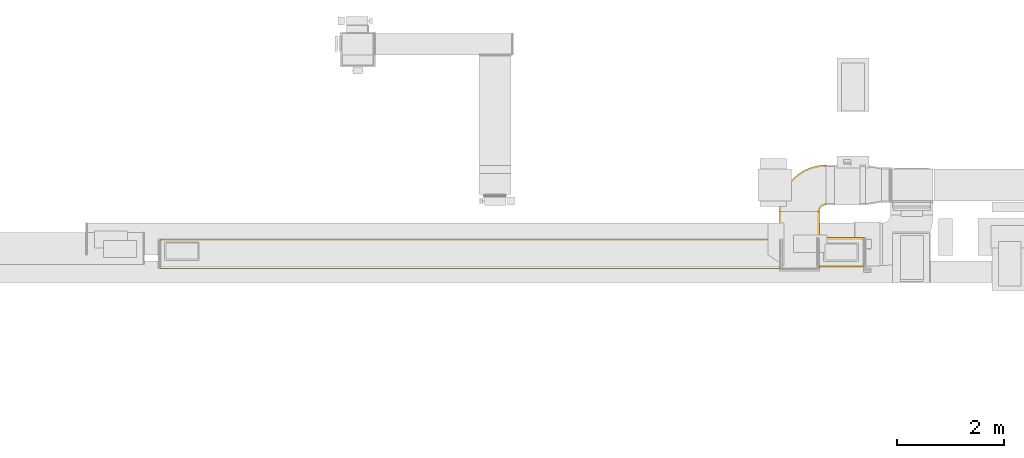
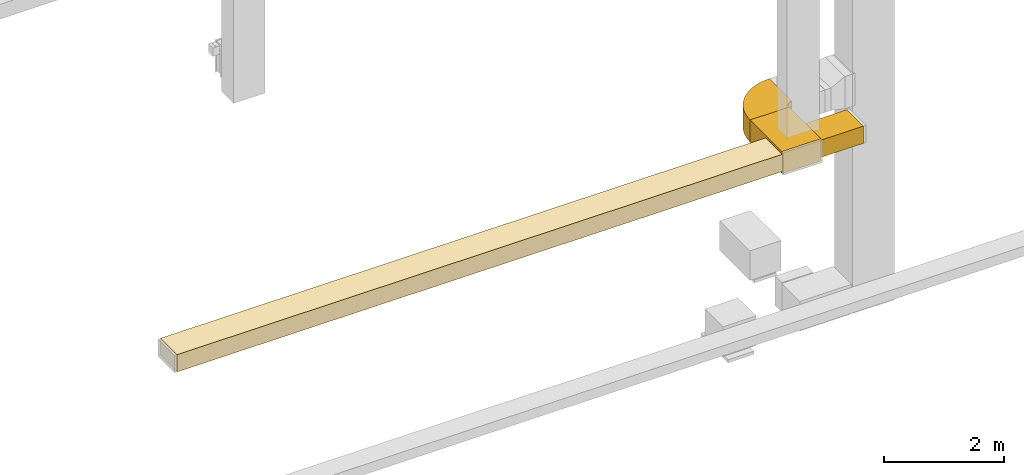
# One storey, part 2 of 29: 4 coverings.
"""IFC2X3 building model written with IfcOpenShell, lengths in millimetres."""

from ifc_helpers import new_model, entity, si_unit, converted_unit, derived_unit, direction, frame, frame_2d, origin, place, context, subcontext, project, spatial, polyline, circle_curve, parameter, trimmed, segment, composite_curve, rectangle, outline, extrude, element, save


model = new_model("IFC2X3")

# Units and contexts
model_context = context("Model", 3, precision=0.01, world=origin(), true_north=direction((6.12303176911189e-17, 1.0)))
body_context = subcontext(model_context, "Body", "Model", "MODEL_VIEW")
ifc_project = project(units=[si_unit("LENGTHUNIT", "METRE", prefix="MILLI"), si_unit("AREAUNIT", "SQUARE_METRE"), si_unit("VOLUMEUNIT", "CUBIC_METRE"), converted_unit("PLANEANGLEUNIT", "DEGREE", entity("IfcRatioMeasure", 0.0174532925199433), si_unit("PLANEANGLEUNIT", "RADIAN"), dimensions=[0, 0, 0, 0, 0, 0, 0]), si_unit("MASSUNIT", "GRAM", prefix="KILO"), derived_unit("MASSDENSITYUNIT", [(si_unit("MASSUNIT", "GRAM", prefix="KILO"), 1), (si_unit("LENGTHUNIT", "METRE"), -3)]), derived_unit("MOMENTOFINERTIAUNIT", [(si_unit("LENGTHUNIT", "METRE"), 4)]), si_unit("TIMEUNIT", "SECOND"), si_unit("FREQUENCYUNIT", "HERTZ"), si_unit("THERMODYNAMICTEMPERATUREUNIT", "DEGREE_CELSIUS"), derived_unit("THERMALTRANSMITTANCEUNIT", [(si_unit("MASSUNIT", "GRAM", prefix="KILO"), 1), (si_unit("THERMODYNAMICTEMPERATUREUNIT", "KELVIN"), -1), (si_unit("TIMEUNIT", "SECOND"), -3)]), derived_unit("VOLUMETRICFLOWRATEUNIT", [(si_unit("LENGTHUNIT", "METRE"), 3), (si_unit("TIMEUNIT", "SECOND"), -1)]), derived_unit("MASSFLOWRATEUNIT", [(si_unit("MASSUNIT", "GRAM", prefix="KILO"), 1), (si_unit("TIMEUNIT", "SECOND"), -1)]), derived_unit("ROTATIONALFREQUENCYUNIT", [(si_unit("TIMEUNIT", "SECOND"), -1)]), si_unit("ELECTRICCURRENTUNIT", "AMPERE"), si_unit("ELECTRICVOLTAGEUNIT", "VOLT"), si_unit("POWERUNIT", "WATT"), si_unit("FORCEUNIT", "NEWTON", prefix="KILO"), si_unit("ILLUMINANCEUNIT", "LUX"), si_unit("LUMINOUSFLUXUNIT", "LUMEN"), si_unit("LUMINOUSINTENSITYUNIT", "CANDELA"), derived_unit("USERDEFINED", [(si_unit("MASSUNIT", "GRAM", prefix="KILO"), -1), (si_unit("LENGTHUNIT", "METRE"), -2), (si_unit("TIMEUNIT", "SECOND"), 3), (si_unit("LUMINOUSFLUXUNIT", "LUMEN"), 1)]), derived_unit("LINEARVELOCITYUNIT", [(si_unit("LENGTHUNIT", "METRE"), 1), (si_unit("TIMEUNIT", "SECOND"), -1)]), si_unit("PRESSUREUNIT", "PASCAL"), derived_unit("USERDEFINED", [(si_unit("LENGTHUNIT", "METRE"), -2), (si_unit("MASSUNIT", "GRAM", prefix="KILO"), 1), (si_unit("TIMEUNIT", "SECOND"), -2)]), derived_unit("LINEARFORCEUNIT", [(si_unit("MASSUNIT", "GRAM", prefix="KILO"), 1), (si_unit("LENGTHUNIT", "METRE"), 1), (si_unit("TIMEUNIT", "SECOND"), -2), (si_unit("LENGTHUNIT", "METRE"), -1)]), derived_unit("PLANARFORCEUNIT", [(si_unit("MASSUNIT", "GRAM", prefix="KILO"), 1), (si_unit("LENGTHUNIT", "METRE"), 1), (si_unit("TIMEUNIT", "SECOND"), -2), (si_unit("LENGTHUNIT", "METRE"), -2)])], contexts=[model_context])

# Site, building, storey
site_placement = place(None, frame((0.0, -0.00077364408347762, 0.0)))
site = spatial("IfcSite", under=ifc_project, at=site_placement, CompositionType="ELEMENT")
building_placement = place(site_placement, origin())
building = spatial("IfcBuilding", under=site, at=building_placement, CompositionType="ELEMENT")
storey_placement = place(building_placement, origin())
storey = spatial("IfcBuildingStorey", under=building, at=storey_placement, CompositionType="ELEMENT", Elevation=0.0)

# Coverings
covering_1_placement = place(storey_placement, frame((61132.5004629828, 9275.08046605657, 2475.0)))
element("IfcCovering", 1, at=covering_1_placement, inside=storey, PredefinedType="INSULATION", context=body_context, shape_type="SweptSolid", body=[
    extrude(rectangle(XDim=831.78346095215, YDim=550.0, at=frame_2d((-4.34852154285181e-12, 5.40012479177676e-13), x_axis=(1.0, 0.0))), frame((415.891730476079, 275.0, 0.0), z_axis=(0.0, 0.0, 1.0), x_axis=(-1.0, 0.0, 0.0)), (0.0, 0.0, 1.0), 349.999999999999),
])
covering_2_placement = place(storey_placement, frame((48788.4460161583, 9242.33562411096, 2475.0)))
element("IfcCovering", 2, at=covering_2_placement, inside=storey, PredefinedType="INSULATION", context=body_context, shape_type="SweptSolid", body=[
    extrude(rectangle(XDim=11604.0416533364, YDim=550.000000000001, at=frame_2d((4.54747350886464e-12, 0.0), x_axis=(1.0, 0.0))), frame((5802.02095158791, 275.002635600495, 0.0)), (0.0, 0.0, 1.0), 350.0),
])
covering_3_placement = place(storey_placement, frame((60387.5004629828, 9250.08574557039, 2425.0)))
element("IfcCovering", 3, at=covering_3_placement, inside=storey, PredefinedType="INSULATION", context=body_context, shape_type="SweptSolid", body=[
    extrude(rectangle(XDim=1058.41426556729, YDim=750.000000000003, at=frame_2d((1.08002495835535e-12, -4.32009983342141e-12), x_axis=(1.0, 0.0))), frame((375.0, 529.207132783651, 0.0), z_axis=(0.0, 0.0, 1.0), x_axis=(0.0, -1.0, 0.0)), (0.0, 0.0, 1.0), 450.0),
])
covering_4_placement = place(storey_placement, frame((60385.9051907468, 10306.9047389018, 2425.0)))
element("IfcCovering", 4, at=covering_4_placement, inside=storey, PredefinedType="INSULATION", context=body_context, shape_type="SweptSolid", body=[
    extrude(outline(composite_curve([segment(polyline([(-250.0, 125.0), (-250.0, -625.0)]), True, "CONTINUOUS"), segment(trimmed(circle_curve(frame_2d((-250.0, 250.0), x_axis=(1.0, 0.0)), 875.0), [parameter(270.0)], [parameter(0.0)], True, "PARAMETER"), True, "CONTINUOUS"), segment(polyline([(625.0, 250.0), (-125.0, 250.0)]), True, "CONTINUOUS"), segment(trimmed(circle_curve(frame_2d((-250.0, 250.0), x_axis=(1.0, 0.0)), 125.0), [parameter(270.0)], [parameter(360.0)], True, "PARAMETER"), False, "CONTINUOUS")], self_intersect=False)), frame((626.595272235912, 251.595272235913, 0.0), z_axis=(0.0, 0.0, -1.0), x_axis=(0.0, 1.0, 0.0)), (0.0, 0.0, -1.0), 450.0),
])

save(model, "model.ifc")
